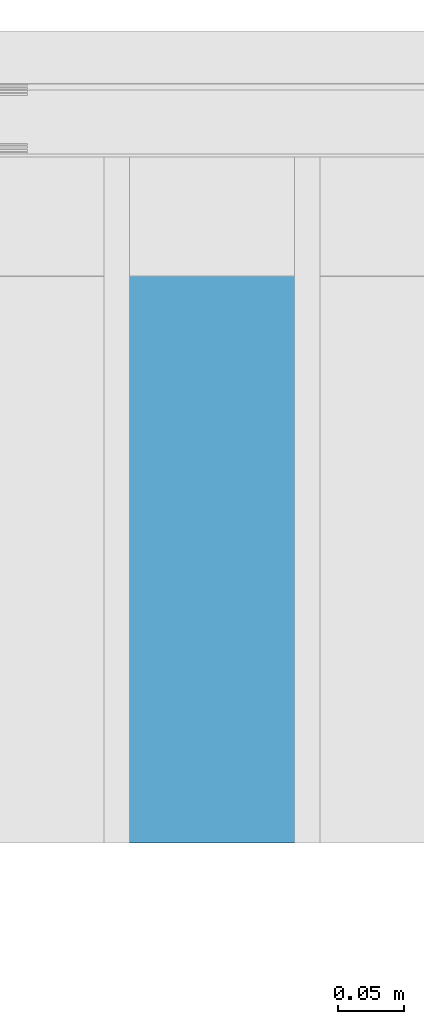
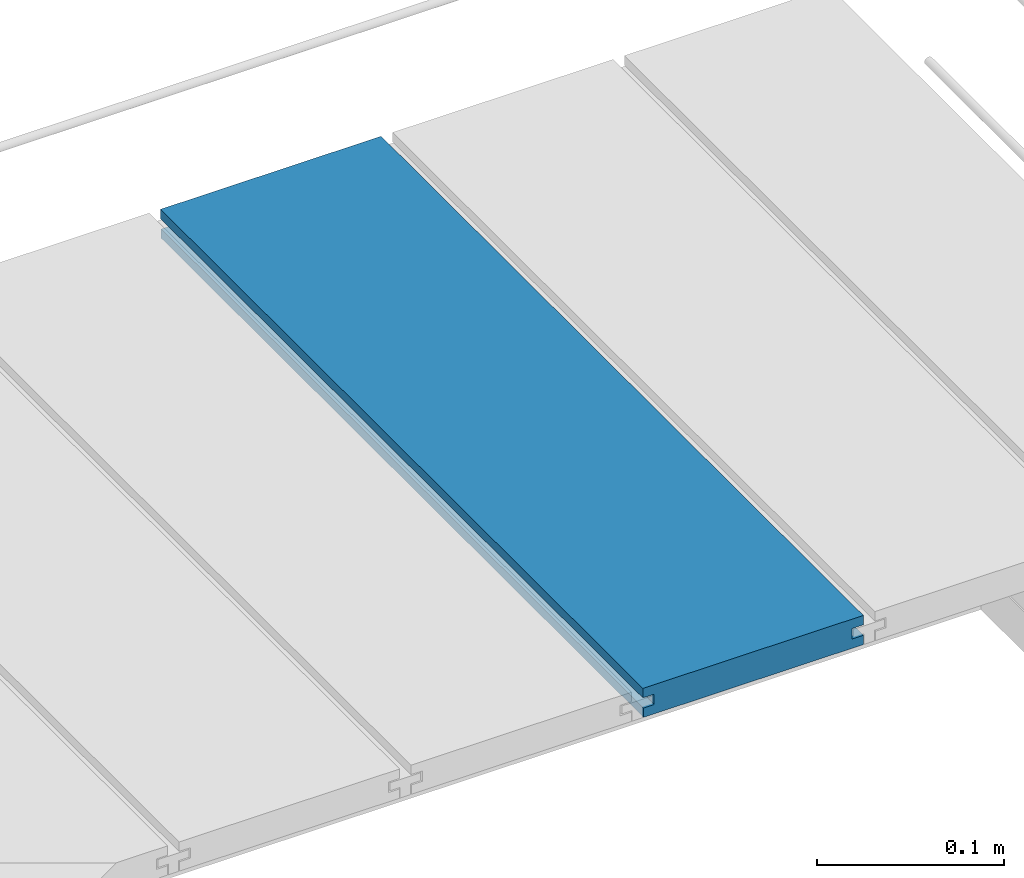
# One storey, part 17 of 33: 1 wall.
"""IFC4 building model written with IfcOpenShell, lengths in feet."""

import ifcopenshell
import ifcopenshell.guid

model = None  # the IFC model being written
_history = None  # IfcOwnerHistory: only IFC2X3 demands one
_inside = {}  # id of a spatial element -> (the spatial element, [elements in it])
_under = {}  # id of a project, library or spatial element -> (it, [spatial elements below it])
_declared = {}  # id of a project -> (the project, [libraries it declares])
_typed = {}  # id of a type object -> (the type object, [elements of that type])
_made_of = {}  # id of a material, layer set ... -> (it, [elements and type objects made of it])


def new_model(schema):
    """Start an empty IFC model of exactly this schema.

    Asked for "IFC4X3", IfcOpenShell would pick the latest addendum, in which some entities
    have other attributes; the version numbers below select the first issue.
    IFC2X3 requires an IfcOwnerHistory on every rooted entity: one is made here for all.
    """
    global model, _history
    if schema == "IFC4X3":
        model = ifcopenshell.file(schema_version=(4, 3, 0, 0))
    else:
        model = ifcopenshell.file(schema=schema)
    _inside.clear()
    _under.clear()
    _declared.clear()
    _typed.clear()
    _made_of.clear()
    _history = None
    if model.schema == "IFC2X3":
        org = make("IfcOrganization", Name="unknown")
        user = make(
            "IfcPersonAndOrganization",
            ThePerson=make("IfcPerson", FamilyName="unknown"),
            TheOrganization=org,
        )
        app = make(
            "IfcApplication",
            ApplicationDeveloper=org,
            Version="unknown",
            ApplicationFullName="unknown",
            ApplicationIdentifier="unknown",
        )
        _history = make(
            "IfcOwnerHistory",
            OwningUser=user,
            OwningApplication=app,
            ChangeAction="ADDED",
            CreationDate=0,
        )
    return model


def make(cls, **values):
    """One entity of the class cls with the attributes given. An attribute that is None is left unset."""
    return model.create_entity(
        cls, **{name: value for name, value in values.items() if value is not None}
    )


def entity(cls, *values):
    """Any entity or typed value of the class cls, its attributes in the order of the schema. None: left unset."""
    e = model.create_entity(cls)
    for i, value in enumerate(values):
        if value is not None:
            e[i] = value
    return e


def rooted(cls, **values):
    """An entity with a GlobalId (a new one), such as an element, a storey or a relation."""
    return make(cls, GlobalId=ifcopenshell.guid.new(), OwnerHistory=_history, **values)


def si_unit(unit_type, name, prefix=None):
    """IfcSIUnit, for example si_unit("LENGTHUNIT", "METRE", prefix="MILLI")."""
    return make("IfcSIUnit", UnitType=unit_type, Prefix=prefix, Name=name)


def converted_unit(unit_type, name, factor, base, dimensions=None, offset=None):
    """IfcConversionBasedUnit, such as the inch: factor (a typed value) times the base unit."""
    return make(
        "IfcConversionBasedUnit"
        if offset is None
        else "IfcConversionBasedUnitWithOffset",
        ConversionOffset=offset,
        Dimensions=None
        if dimensions is None
        else entity("IfcDimensionalExponents", *dimensions),
        UnitType=unit_type,
        Name=name,
        ConversionFactor=make(
            "IfcMeasureWithUnit", ValueComponent=factor, UnitComponent=base
        ),
    )


def derived_unit(unit_type, elements):
    """IfcDerivedUnit: a product of units, each with its exponent."""
    return make(
        "IfcDerivedUnit",
        Elements=[
            make("IfcDerivedUnitElement", Unit=unit, Exponent=power)
            for unit, power in elements
        ],
        UnitType=unit_type,
    )


def assignment(units):
    """IfcUnitAssignment: the units of a project."""
    return None if units is None else make("IfcUnitAssignment", Units=units)


def point(xyz):
    """IfcCartesianPoint."""
    return None if xyz is None else make("IfcCartesianPoint", Coordinates=xyz)


def direction(xyz):
    """IfcDirection."""
    return None if xyz is None else make("IfcDirection", DirectionRatios=xyz)


def frame(location, z_axis=None, x_axis=None):
    """IfcAxis2Placement3D, a coordinate frame: its origin and axes. An axis left out is left unset."""
    return make(
        "IfcAxis2Placement3D",
        Location=point(location),
        Axis=direction(z_axis),
        RefDirection=direction(x_axis),
    )


def origin():
    """The frame at (0, 0, 0) with its axes left unset."""
    return frame((0.0, 0.0, 0.0))


def place(relative_to, where):
    """IfcLocalPlacement: puts the frame where relative to a parent placement (None: the world)."""
    return make(
        "IfcLocalPlacement", PlacementRelTo=relative_to, RelativePlacement=where
    )


def context(
    kind, dimensions, precision=None, world=None, true_north=None, identifier=None
):
    """IfcGeometricRepresentationContext, for example the 3D "Model" context."""
    return make(
        "IfcGeometricRepresentationContext",
        ContextIdentifier=identifier,
        ContextType=kind,
        CoordinateSpaceDimension=dimensions,
        Precision=precision,
        WorldCoordinateSystem=world,
        TrueNorth=true_north,
    )


def subcontext(parent, identifier, kind, view, scale=None):
    """IfcGeometricRepresentationSubContext, for example "Body" below "Model"."""
    return make(
        "IfcGeometricRepresentationSubContext",
        ContextIdentifier=identifier,
        ContextType=kind,
        ParentContext=parent,
        TargetScale=scale,
        TargetView=view,
    )


def project(units=None, contexts=None):
    """IfcProject with its units and contexts."""
    return rooted(
        "IfcProject",
        Name="project",
        RepresentationContexts=contexts,
        UnitsInContext=assignment(units),
    )


def spatial(cls, under=None, at=None, **own):
    """A site, building, storey or space (cls), placed at a placement, below another one or the project."""
    s = rooted(cls, ObjectPlacement=at, **own)
    if under is not None:
        _under.setdefault(under.id(), (under, []))[1].append(s)
    return s


def shape(context_of_items, identifier, shape_type, items):
    """IfcShapeRepresentation: the items that make up one representation, for example the "Body"."""
    return make(
        "IfcShapeRepresentation",
        ContextOfItems=context_of_items,
        RepresentationIdentifier=identifier,
        RepresentationType=shape_type,
        Items=items,
    )


def material(Name=None, Category=None):
    """IfcMaterial."""
    return make("IfcMaterial", Name=Name, Category=Category)


def made_of(thing, what):
    """Note that an element or type object is made of a material, layer set ...; save() writes the relation."""
    if what is not None:
        _made_of.setdefault(what.id(), (what, []))[1].append(thing)
    return thing


def type_object(cls, material=None, **own):
    """A type object (cls), such as IfcWallType, which elements share."""
    return made_of(rooted(cls, **own), material)


def element(
    cls,
    number,
    at=None,
    inside=None,
    cuts=None,
    type_object=None,
    material=None,
    context=None,
    identifier="Body",
    shape_type=None,
    held_by="IfcProductDefinitionShape",
    body=None,
    shapes=None,
    **own,
):
    """One element of the class cls, such as IfcWall. Its Tag is "e" and its number.

    at: its placement. inside: the storey or other place that contains it. cuts: it is an
    opening in that element (IfcRelVoidsElement). A single representation is given by context,
    identifier, shape_type and body (its items); several are given by shapes. held_by: the class
    of the entity that holds the representations. save() writes the other relations.
    """
    e = rooted(cls, Tag="e%d" % number, ObjectPlacement=at, **own)
    if body is not None:
        shapes = [shape(context, identifier, shape_type, body)]
    if shapes is not None:
        e.Representation = make(held_by, Representations=shapes)
    if inside is not None:
        _inside.setdefault(inside.id(), (inside, []))[1].append(e)
    if cuts is not None:
        rooted(
            "IfcRelVoidsElement", RelatingBuildingElement=cuts, RelatedOpeningElement=e
        )
    if type_object is not None:
        _typed.setdefault(type_object.id(), (type_object, []))[1].append(e)
    return made_of(e, material)


def aggregate(whole, parts):
    """IfcRelAggregates: a whole, such as a stair, and the parts it consists of."""
    return rooted("IfcRelAggregates", RelatingObject=whole, RelatedObjects=parts)


def save(model, path):
    """Write the relations noted so far, then the file.

    IfcRelAggregates (storeys below a building ...), IfcRelContainedInSpatialStructure (elements
    in a storey), IfcRelDefinesByType, IfcRelAssociatesMaterial and IfcRelDeclares: one each for
    every whole, place, type object, material and project.
    """
    for whole, parts in _under.values():
        aggregate(whole, parts)
    for where, things in _inside.values():
        rooted(
            "IfcRelContainedInSpatialStructure",
            RelatedElements=things,
            RelatingStructure=where,
        )
    for kind, things in _typed.values():
        rooted("IfcRelDefinesByType", RelatedObjects=things, RelatingType=kind)
    for what, things in _made_of.values():
        rooted("IfcRelAssociatesMaterial", RelatedObjects=things, RelatingMaterial=what)
    for by, libraries in _declared.values():
        rooted("IfcRelDeclares", RelatingContext=by, RelatedDefinitions=libraries)
    model.write(path)


model = new_model("IFC4")

# Units and contexts
model_context = context("Model", 3, precision=0.0001, world=origin(), true_north=direction((6.12303176911189e-17, 1.0)))
body_context = subcontext(model_context, "Body", "Model", "MODEL_VIEW")
ifc_project = project(units=[converted_unit("LENGTHUNIT", "FOOT", entity("IfcRatioMeasure", 0.3048), si_unit("LENGTHUNIT", "METRE"), dimensions=[1, 0, 0, 0, 0, 0, 0]), converted_unit("AREAUNIT", "SQUARE FOOT", entity("IfcRatioMeasure", 0.09290304), si_unit("AREAUNIT", "SQUARE_METRE"), dimensions=[2, 0, 0, 0, 0, 0, 0]), converted_unit("VOLUMEUNIT", "CUBIC FOOT", entity("IfcRatioMeasure", 0.028316846592), si_unit("VOLUMEUNIT", "CUBIC_METRE"), dimensions=[3, 0, 0, 0, 0, 0, 0]), converted_unit("PLANEANGLEUNIT", "DEGREE", entity("IfcRatioMeasure", 0.0174532925199433), si_unit("PLANEANGLEUNIT", "RADIAN"), dimensions=[0, 0, 0, 0, 0, 0, 0]), si_unit("MASSUNIT", "GRAM", prefix="KILO"), derived_unit("MASSDENSITYUNIT", [(si_unit("MASSUNIT", "GRAM", prefix="KILO"), 1), (si_unit("LENGTHUNIT", "METRE"), -3)]), derived_unit("MOMENTOFINERTIAUNIT", [(si_unit("LENGTHUNIT", "METRE"), 4)]), si_unit("TIMEUNIT", "SECOND"), si_unit("FREQUENCYUNIT", "HERTZ"), si_unit("THERMODYNAMICTEMPERATUREUNIT", "DEGREE_CELSIUS"), derived_unit("THERMALTRANSMITTANCEUNIT", [(si_unit("MASSUNIT", "GRAM", prefix="KILO"), 1), (si_unit("THERMODYNAMICTEMPERATUREUNIT", "KELVIN"), -1), (si_unit("TIMEUNIT", "SECOND"), -3)]), derived_unit("VOLUMETRICFLOWRATEUNIT", [(si_unit("LENGTHUNIT", "METRE"), 3), (si_unit("TIMEUNIT", "SECOND"), -1)]), si_unit("ELECTRICCURRENTUNIT", "AMPERE"), si_unit("ELECTRICVOLTAGEUNIT", "VOLT"), si_unit("POWERUNIT", "WATT"), si_unit("FORCEUNIT", "NEWTON"), si_unit("ILLUMINANCEUNIT", "LUX"), si_unit("LUMINOUSFLUXUNIT", "LUMEN"), si_unit("LUMINOUSINTENSITYUNIT", "CANDELA"), derived_unit("USERDEFINED", [(si_unit("MASSUNIT", "GRAM", prefix="KILO"), -1), (si_unit("LENGTHUNIT", "METRE"), -2), (si_unit("TIMEUNIT", "SECOND"), 3), (si_unit("LUMINOUSFLUXUNIT", "LUMEN"), 1)]), derived_unit("LINEARVELOCITYUNIT", [(si_unit("LENGTHUNIT", "METRE"), 1), (si_unit("TIMEUNIT", "SECOND"), -1)]), si_unit("PRESSUREUNIT", "PASCAL"), derived_unit("USERDEFINED", [(si_unit("LENGTHUNIT", "METRE"), -2), (si_unit("MASSUNIT", "GRAM", prefix="KILO"), 1), (si_unit("TIMEUNIT", "SECOND"), -2)]), derived_unit("LINEARFORCEUNIT", [(si_unit("MASSUNIT", "GRAM", prefix="KILO"), 1), (si_unit("LENGTHUNIT", "METRE"), 1), (si_unit("TIMEUNIT", "SECOND"), -2), (si_unit("LENGTHUNIT", "METRE"), -1)]), derived_unit("PLANARFORCEUNIT", [(si_unit("MASSUNIT", "GRAM", prefix="KILO"), 1), (si_unit("LENGTHUNIT", "METRE"), 1), (si_unit("TIMEUNIT", "SECOND"), -2), (si_unit("LENGTHUNIT", "METRE"), -2)])], contexts=[model_context])

# Site, building, storey
site_placement = place(None, origin())
site = spatial("IfcSite", under=ifc_project, at=site_placement, CompositionType="ELEMENT")
building_placement = place(site_placement, origin())
building = spatial("IfcBuilding", under=site, at=building_placement, CompositionType="ELEMENT")
storey_placement = place(building_placement, frame((0.0, 0.0, 10.0)))
storey = spatial("IfcBuildingStorey", under=building, at=storey_placement, Name="2ND FLOOR", CompositionType="ELEMENT", Elevation=10.0000000000002)

# Wall
ifc_material = material(Name="COMPOSITE DECKING W/ HIDDEN FASTENERS", Category="Materials")
wall_type = type_object("IfcWallType", Name="Generic Models 636:Generic Models 1", PredefinedType="NOTDEFINED", material=ifc_material)
wall_placement = place(storey_placement, frame((1492.94072175076, 3.0461139299927, 0.68290215715013), z_axis=(0.0, 0.0, 1.0), x_axis=(0.0, 1.0, 0.0)))
cartesian_point_1 = entity("IfcCartesianPoint", [1.69226081335874, -0.446740923891412, 0.0])
vertex_point_1 = entity("IfcVertexPoint", cartesian_point_1)
cartesian_point_2 = entity("IfcCartesianPoint", [1.69226081335874, -0.00132475379450625, 0.0])
vertex_point_2 = entity("IfcVertexPoint", cartesian_point_2)
ifc_direction_1 = entity("IfcDirection", [0.0, 1.0, 0.0])
edge_curve_1 = entity("IfcEdgeCurve", vertex_point_1, vertex_point_2, entity("IfcTrimmedCurve", entity("IfcLine", cartesian_point_1, entity("IfcVector", ifc_direction_1, 1.0)), [cartesian_point_1], [cartesian_point_2], True, "CARTESIAN"), True)
cartesian_point_3 = entity("IfcCartesianPoint", [1.69226081335874, -0.00132475379450625, 0.0198779960861479])
vertex_point_3 = entity("IfcVertexPoint", cartesian_point_3)
ifc_direction_2 = entity("IfcDirection", [0.0, 0.0, 1.0])
edge_curve_2 = entity("IfcEdgeCurve", vertex_point_2, vertex_point_3, entity("IfcTrimmedCurve", entity("IfcLine", cartesian_point_2, entity("IfcVector", ifc_direction_2, 1.0)), [cartesian_point_2], [cartesian_point_3], True, "CARTESIAN"), True)
cartesian_point_4 = entity("IfcCartesianPoint", [1.69226081335874, -0.0228400010807945, 0.0198779960861479])
vertex_point_4 = entity("IfcVertexPoint", cartesian_point_4)
ifc_direction_3 = entity("IfcDirection", [0.0, -1.0, 0.0])
edge_curve_3 = entity("IfcEdgeCurve", vertex_point_3, vertex_point_4, entity("IfcTrimmedCurve", entity("IfcLine", cartesian_point_3, entity("IfcVector", ifc_direction_3, 1.0)), [cartesian_point_3], [cartesian_point_4], True, "CARTESIAN"), True)
cartesian_point_5 = entity("IfcCartesianPoint", [1.69226081335874, -0.0228400010807945, 0.0422987663426522])
vertex_point_5 = entity("IfcVertexPoint", cartesian_point_5)
edge_curve_4 = entity("IfcEdgeCurve", vertex_point_4, vertex_point_5, entity("IfcTrimmedCurve", entity("IfcLine", cartesian_point_4, entity("IfcVector", ifc_direction_2, 1.0)), [cartesian_point_4], [cartesian_point_5], True, "CARTESIAN"), True)
cartesian_point_6 = entity("IfcCartesianPoint", [1.69226081335874, 0.0, 0.0422987663426522])
vertex_point_6 = entity("IfcVertexPoint", cartesian_point_6)
edge_curve_5 = entity("IfcEdgeCurve", vertex_point_5, vertex_point_6, entity("IfcTrimmedCurve", entity("IfcLine", cartesian_point_5, entity("IfcVector", ifc_direction_1, 1.0)), [cartesian_point_5], [cartesian_point_6], True, "CARTESIAN"), True)
cartesian_point_7 = entity("IfcCartesianPoint", [1.69226081335874, 0.0, 0.0625000000000551])
vertex_point_7 = entity("IfcVertexPoint", cartesian_point_7)
edge_curve_6 = entity("IfcEdgeCurve", vertex_point_6, vertex_point_7, entity("IfcTrimmedCurve", entity("IfcLine", cartesian_point_6, entity("IfcVector", ifc_direction_2, 1.0)), [cartesian_point_6], [cartesian_point_7], True, "CARTESIAN"), True)
cartesian_point_8 = entity("IfcCartesianPoint", [1.69226081335874, -0.446740923891639, 0.0625])
vertex_point_8 = entity("IfcVertexPoint", cartesian_point_8)
edge_curve_7 = entity("IfcEdgeCurve", vertex_point_7, vertex_point_8, entity("IfcTrimmedCurve", entity("IfcLine", cartesian_point_7, entity("IfcVector", ifc_direction_3, 1.0)), [cartesian_point_7], [cartesian_point_8], True, "CARTESIAN"), True)
cartesian_point_9 = entity("IfcCartesianPoint", [1.69226081335874, -0.446740923891639, 0.0422987663426522])
vertex_point_9 = entity("IfcVertexPoint", cartesian_point_9)
ifc_direction_4 = entity("IfcDirection", [0.0, 0.0, -1.0])
edge_curve_8 = entity("IfcEdgeCurve", vertex_point_8, vertex_point_9, entity("IfcTrimmedCurve", entity("IfcLine", cartesian_point_8, entity("IfcVector", ifc_direction_4, 1.0)), [cartesian_point_8], [cartesian_point_9], True, "CARTESIAN"), True)
cartesian_point_10 = entity("IfcCartesianPoint", [1.69226081335874, -0.423900922810617, 0.0422987663426522])
vertex_point_10 = entity("IfcVertexPoint", cartesian_point_10)
edge_curve_9 = entity("IfcEdgeCurve", vertex_point_9, vertex_point_10, entity("IfcTrimmedCurve", entity("IfcLine", cartesian_point_9, entity("IfcVector", ifc_direction_1, 1.0)), [cartesian_point_9], [cartesian_point_10], True, "CARTESIAN"), True)
cartesian_point_11 = entity("IfcCartesianPoint", [1.69226081335874, -0.423900922810617, 0.0198779960861479])
vertex_point_11 = entity("IfcVertexPoint", cartesian_point_11)
edge_curve_10 = entity("IfcEdgeCurve", vertex_point_10, vertex_point_11, entity("IfcTrimmedCurve", entity("IfcLine", cartesian_point_10, entity("IfcVector", ifc_direction_4, 1.0)), [cartesian_point_10], [cartesian_point_11], True, "CARTESIAN"), True)
cartesian_point_12 = entity("IfcCartesianPoint", [1.69226081335874, -0.446740923891412, 0.0198779960861479])
vertex_point_12 = entity("IfcVertexPoint", cartesian_point_12)
edge_curve_11 = entity("IfcEdgeCurve", vertex_point_11, vertex_point_12, entity("IfcTrimmedCurve", entity("IfcLine", cartesian_point_11, entity("IfcVector", ifc_direction_3, 1.0)), [cartesian_point_11], [cartesian_point_12], True, "CARTESIAN"), True)
edge_curve_12 = entity("IfcEdgeCurve", vertex_point_12, vertex_point_1, entity("IfcTrimmedCurve", entity("IfcLine", cartesian_point_12, entity("IfcVector", ifc_direction_4, 1.0)), [cartesian_point_12], [cartesian_point_1], True, "CARTESIAN"), True)
ifc_direction_5 = entity("IfcDirection", [1.0, 0.0, 0.0])
cartesian_point_13 = entity("IfcCartesianPoint", [0.0, -0.446740923891412, 0.0])
vertex_point_13 = entity("IfcVertexPoint", cartesian_point_13)
cartesian_point_14 = entity("IfcCartesianPoint", [0.0, -0.446740923891412, 0.0198779960861479])
vertex_point_14 = entity("IfcVertexPoint", cartesian_point_14)
edge_curve_13 = entity("IfcEdgeCurve", vertex_point_13, vertex_point_14, entity("IfcTrimmedCurve", entity("IfcLine", cartesian_point_13, entity("IfcVector", ifc_direction_2, 1.0)), [cartesian_point_13], [cartesian_point_14], True, "CARTESIAN"), True)
cartesian_point_15 = entity("IfcCartesianPoint", [0.0, -0.423900922810617, 0.0198779960861479])
vertex_point_15 = entity("IfcVertexPoint", cartesian_point_15)
edge_curve_14 = entity("IfcEdgeCurve", vertex_point_14, vertex_point_15, entity("IfcTrimmedCurve", entity("IfcLine", cartesian_point_14, entity("IfcVector", ifc_direction_1, 1.0)), [cartesian_point_14], [cartesian_point_15], True, "CARTESIAN"), True)
cartesian_point_16 = entity("IfcCartesianPoint", [0.0, -0.423900922810617, 0.0422987663426522])
vertex_point_16 = entity("IfcVertexPoint", cartesian_point_16)
edge_curve_15 = entity("IfcEdgeCurve", vertex_point_15, vertex_point_16, entity("IfcTrimmedCurve", entity("IfcLine", cartesian_point_15, entity("IfcVector", ifc_direction_2, 1.0)), [cartesian_point_15], [cartesian_point_16], True, "CARTESIAN"), True)
cartesian_point_17 = entity("IfcCartesianPoint", [0.0, -0.446740923891639, 0.0422987663426522])
vertex_point_17 = entity("IfcVertexPoint", cartesian_point_17)
edge_curve_16 = entity("IfcEdgeCurve", vertex_point_16, vertex_point_17, entity("IfcTrimmedCurve", entity("IfcLine", cartesian_point_16, entity("IfcVector", ifc_direction_3, 1.0)), [cartesian_point_16], [cartesian_point_17], True, "CARTESIAN"), True)
cartesian_point_18 = entity("IfcCartesianPoint", [0.0, -0.446740923891639, 0.0625])
vertex_point_18 = entity("IfcVertexPoint", cartesian_point_18)
edge_curve_17 = entity("IfcEdgeCurve", vertex_point_17, vertex_point_18, entity("IfcTrimmedCurve", entity("IfcLine", cartesian_point_17, entity("IfcVector", ifc_direction_2, 1.0)), [cartesian_point_17], [cartesian_point_18], True, "CARTESIAN"), True)
cartesian_point_19 = entity("IfcCartesianPoint", [0.0, 0.0, 0.0625000000000551])
vertex_point_19 = entity("IfcVertexPoint", cartesian_point_19)
edge_curve_18 = entity("IfcEdgeCurve", vertex_point_18, vertex_point_19, entity("IfcTrimmedCurve", entity("IfcLine", cartesian_point_18, entity("IfcVector", ifc_direction_1, 1.0)), [cartesian_point_18], [cartesian_point_19], True, "CARTESIAN"), True)
cartesian_point_20 = entity("IfcCartesianPoint", [0.0, 0.0, 0.0422987663426522])
vertex_point_20 = entity("IfcVertexPoint", cartesian_point_20)
edge_curve_19 = entity("IfcEdgeCurve", vertex_point_19, vertex_point_20, entity("IfcTrimmedCurve", entity("IfcLine", cartesian_point_19, entity("IfcVector", ifc_direction_4, 1.0)), [cartesian_point_19], [cartesian_point_20], True, "CARTESIAN"), True)
cartesian_point_21 = entity("IfcCartesianPoint", [0.0, -0.0228400010807945, 0.0422987663426522])
vertex_point_21 = entity("IfcVertexPoint", cartesian_point_21)
edge_curve_20 = entity("IfcEdgeCurve", vertex_point_20, vertex_point_21, entity("IfcTrimmedCurve", entity("IfcLine", cartesian_point_20, entity("IfcVector", ifc_direction_3, 1.0)), [cartesian_point_20], [cartesian_point_21], True, "CARTESIAN"), True)
cartesian_point_22 = entity("IfcCartesianPoint", [0.0, -0.0228400010807945, 0.0198779960861479])
vertex_point_22 = entity("IfcVertexPoint", cartesian_point_22)
edge_curve_21 = entity("IfcEdgeCurve", vertex_point_21, vertex_point_22, entity("IfcTrimmedCurve", entity("IfcLine", cartesian_point_21, entity("IfcVector", ifc_direction_4, 1.0)), [cartesian_point_21], [cartesian_point_22], True, "CARTESIAN"), True)
cartesian_point_23 = entity("IfcCartesianPoint", [0.0, -0.00132475379450625, 0.0198779960861479])
vertex_point_23 = entity("IfcVertexPoint", cartesian_point_23)
edge_curve_22 = entity("IfcEdgeCurve", vertex_point_22, vertex_point_23, entity("IfcTrimmedCurve", entity("IfcLine", cartesian_point_22, entity("IfcVector", ifc_direction_1, 1.0)), [cartesian_point_22], [cartesian_point_23], True, "CARTESIAN"), True)
cartesian_point_24 = entity("IfcCartesianPoint", [0.0, -0.00132475379450625, 0.0])
vertex_point_24 = entity("IfcVertexPoint", cartesian_point_24)
edge_curve_23 = entity("IfcEdgeCurve", vertex_point_23, vertex_point_24, entity("IfcTrimmedCurve", entity("IfcLine", cartesian_point_23, entity("IfcVector", ifc_direction_4, 1.0)), [cartesian_point_23], [cartesian_point_24], True, "CARTESIAN"), True)
edge_curve_24 = entity("IfcEdgeCurve", vertex_point_24, vertex_point_13, entity("IfcTrimmedCurve", entity("IfcLine", cartesian_point_24, entity("IfcVector", ifc_direction_3, 1.0)), [cartesian_point_24], [cartesian_point_13], True, "CARTESIAN"), True)
ifc_direction_6 = entity("IfcDirection", [-1.0, 0.0, 0.0])
edge_curve_25 = entity("IfcEdgeCurve", vertex_point_13, vertex_point_1, entity("IfcTrimmedCurve", entity("IfcLine", cartesian_point_13, entity("IfcVector", ifc_direction_5, 1.0)), [cartesian_point_13], [cartesian_point_1], True, "CARTESIAN"), True)
edge_curve_26 = entity("IfcEdgeCurve", vertex_point_12, vertex_point_14, entity("IfcTrimmedCurve", entity("IfcLine", cartesian_point_14, entity("IfcVector", ifc_direction_6, 1.0)), [cartesian_point_12], [cartesian_point_14], True, "CARTESIAN"), True)
edge_curve_27 = entity("IfcEdgeCurve", vertex_point_18, vertex_point_8, entity("IfcTrimmedCurve", entity("IfcLine", cartesian_point_18, entity("IfcVector", ifc_direction_5, 1.0)), [cartesian_point_18], [cartesian_point_8], True, "CARTESIAN"), True)
edge_curve_28 = entity("IfcEdgeCurve", vertex_point_7, vertex_point_19, entity("IfcTrimmedCurve", entity("IfcLine", cartesian_point_19, entity("IfcVector", ifc_direction_6, 1.0)), [cartesian_point_7], [cartesian_point_19], True, "CARTESIAN"), True)
edge_curve_29 = entity("IfcEdgeCurve", vertex_point_6, vertex_point_20, entity("IfcTrimmedCurve", entity("IfcLine", cartesian_point_20, entity("IfcVector", ifc_direction_6, 1.0)), [cartesian_point_6], [cartesian_point_20], True, "CARTESIAN"), True)
edge_curve_30 = entity("IfcEdgeCurve", vertex_point_24, vertex_point_2, entity("IfcTrimmedCurve", entity("IfcLine", cartesian_point_24, entity("IfcVector", ifc_direction_5, 1.0)), [cartesian_point_24], [cartesian_point_2], True, "CARTESIAN"), True)
edge_curve_31 = entity("IfcEdgeCurve", vertex_point_17, vertex_point_9, entity("IfcTrimmedCurve", entity("IfcLine", cartesian_point_17, entity("IfcVector", ifc_direction_5, 1.0)), [cartesian_point_17], [cartesian_point_9], True, "CARTESIAN"), True)
edge_curve_32 = entity("IfcEdgeCurve", vertex_point_5, vertex_point_21, entity("IfcTrimmedCurve", entity("IfcLine", cartesian_point_21, entity("IfcVector", ifc_direction_6, 1.0)), [cartesian_point_5], [cartesian_point_21], True, "CARTESIAN"), True)
edge_curve_33 = entity("IfcEdgeCurve", vertex_point_4, vertex_point_22, entity("IfcTrimmedCurve", entity("IfcLine", cartesian_point_22, entity("IfcVector", ifc_direction_6, 1.0)), [cartesian_point_4], [cartesian_point_22], True, "CARTESIAN"), True)
edge_curve_34 = entity("IfcEdgeCurve", vertex_point_3, vertex_point_23, entity("IfcTrimmedCurve", entity("IfcLine", cartesian_point_23, entity("IfcVector", ifc_direction_6, 1.0)), [cartesian_point_3], [cartesian_point_23], True, "CARTESIAN"), True)
edge_curve_35 = entity("IfcEdgeCurve", vertex_point_11, vertex_point_15, entity("IfcTrimmedCurve", entity("IfcLine", cartesian_point_15, entity("IfcVector", ifc_direction_6, 1.0)), [cartesian_point_11], [cartesian_point_15], True, "CARTESIAN"), True)
edge_curve_36 = entity("IfcEdgeCurve", vertex_point_10, vertex_point_16, entity("IfcTrimmedCurve", entity("IfcLine", cartesian_point_16, entity("IfcVector", ifc_direction_6, 1.0)), [cartesian_point_10], [cartesian_point_16], True, "CARTESIAN"), True)
element("IfcWall", 1, at=wall_placement, inside=storey, type_object=wall_type, material=ifc_material, Name="Generic Models 636:Generic Models 1", ObjectType="Generic Models 636:Generic Models 1", PredefinedType="NOTDEFINED", context=body_context, shape_type="AdvancedBrep", body=[
    entity("IfcAdvancedBrep", entity("IfcClosedShell", [entity("IfcAdvancedFace", [entity("IfcFaceOuterBound", entity("IfcEdgeLoop", [entity("IfcOrientedEdge", None, None, edge_curve_1, True), entity("IfcOrientedEdge", None, None, edge_curve_2, True), entity("IfcOrientedEdge", None, None, edge_curve_3, True), entity("IfcOrientedEdge", None, None, edge_curve_4, True), entity("IfcOrientedEdge", None, None, edge_curve_5, True), entity("IfcOrientedEdge", None, None, edge_curve_6, True), entity("IfcOrientedEdge", None, None, edge_curve_7, True), entity("IfcOrientedEdge", None, None, edge_curve_8, True), entity("IfcOrientedEdge", None, None, edge_curve_9, True), entity("IfcOrientedEdge", None, None, edge_curve_10, True), entity("IfcOrientedEdge", None, None, edge_curve_11, True), entity("IfcOrientedEdge", None, None, edge_curve_12, True)]), True)], entity("IfcPlane", entity("IfcAxis2Placement3D", entity("IfcCartesianPoint", [1.69226081335874, -0.446740923891412, -0.0208333333328241]), ifc_direction_5, ifc_direction_4)), True), entity("IfcAdvancedFace", [entity("IfcFaceOuterBound", entity("IfcEdgeLoop", [entity("IfcOrientedEdge", None, None, edge_curve_13, True), entity("IfcOrientedEdge", None, None, edge_curve_14, True), entity("IfcOrientedEdge", None, None, edge_curve_15, True), entity("IfcOrientedEdge", None, None, edge_curve_16, True), entity("IfcOrientedEdge", None, None, edge_curve_17, True), entity("IfcOrientedEdge", None, None, edge_curve_18, True), entity("IfcOrientedEdge", None, None, edge_curve_19, True), entity("IfcOrientedEdge", None, None, edge_curve_20, True), entity("IfcOrientedEdge", None, None, edge_curve_21, True), entity("IfcOrientedEdge", None, None, edge_curve_22, True), entity("IfcOrientedEdge", None, None, edge_curve_23, True), entity("IfcOrientedEdge", None, None, edge_curve_24, True)]), True)], entity("IfcPlane", entity("IfcAxis2Placement3D", entity("IfcCartesianPoint", [0.0, -0.446740923891412, -0.0208333333328241]), ifc_direction_6, ifc_direction_2)), True), entity("IfcAdvancedFace", [entity("IfcFaceOuterBound", entity("IfcEdgeLoop", [entity("IfcOrientedEdge", None, None, edge_curve_13, False), entity("IfcOrientedEdge", None, None, edge_curve_25, True), entity("IfcOrientedEdge", None, None, edge_curve_12, False), entity("IfcOrientedEdge", None, None, edge_curve_26, True)]), True)], entity("IfcPlane", entity("IfcAxis2Placement3D", cartesian_point_13, ifc_direction_3, ifc_direction_5)), True), entity("IfcAdvancedFace", [entity("IfcFaceOuterBound", entity("IfcEdgeLoop", [entity("IfcOrientedEdge", None, None, edge_curve_18, False), entity("IfcOrientedEdge", None, None, edge_curve_27, True), entity("IfcOrientedEdge", None, None, edge_curve_7, False), entity("IfcOrientedEdge", None, None, edge_curve_28, True)]), True)], entity("IfcPlane", entity("IfcAxis2Placement3D", cartesian_point_18, ifc_direction_2, ifc_direction_5)), True), entity("IfcAdvancedFace", [entity("IfcFaceOuterBound", entity("IfcEdgeLoop", [entity("IfcOrientedEdge", None, None, edge_curve_19, False), entity("IfcOrientedEdge", None, None, edge_curve_28, False), entity("IfcOrientedEdge", None, None, edge_curve_6, False), entity("IfcOrientedEdge", None, None, edge_curve_29, True)]), True)], entity("IfcPlane", entity("IfcAxis2Placement3D", cartesian_point_19, ifc_direction_1, ifc_direction_5)), True), entity("IfcAdvancedFace", [entity("IfcFaceOuterBound", entity("IfcEdgeLoop", [entity("IfcOrientedEdge", None, None, edge_curve_24, False), entity("IfcOrientedEdge", None, None, edge_curve_30, True), entity("IfcOrientedEdge", None, None, edge_curve_1, False), entity("IfcOrientedEdge", None, None, edge_curve_25, False)]), True)], entity("IfcPlane", entity("IfcAxis2Placement3D", cartesian_point_24, ifc_direction_4, ifc_direction_5)), True), entity("IfcAdvancedFace", [entity("IfcFaceOuterBound", entity("IfcEdgeLoop", [entity("IfcOrientedEdge", None, None, edge_curve_17, False), entity("IfcOrientedEdge", None, None, edge_curve_31, True), entity("IfcOrientedEdge", None, None, edge_curve_8, False), entity("IfcOrientedEdge", None, None, edge_curve_27, False)]), True)], entity("IfcPlane", entity("IfcAxis2Placement3D", cartesian_point_17, ifc_direction_3, ifc_direction_5)), True), entity("IfcAdvancedFace", [entity("IfcFaceOuterBound", entity("IfcEdgeLoop", [entity("IfcOrientedEdge", None, None, edge_curve_20, False), entity("IfcOrientedEdge", None, None, edge_curve_29, False), entity("IfcOrientedEdge", None, None, edge_curve_5, False), entity("IfcOrientedEdge", None, None, edge_curve_32, True)]), True)], entity("IfcPlane", entity("IfcAxis2Placement3D", cartesian_point_20, ifc_direction_4, ifc_direction_5)), True), entity("IfcAdvancedFace", [entity("IfcFaceOuterBound", entity("IfcEdgeLoop", [entity("IfcOrientedEdge", None, None, edge_curve_21, False), entity("IfcOrientedEdge", None, None, edge_curve_32, False), entity("IfcOrientedEdge", None, None, edge_curve_4, False), entity("IfcOrientedEdge", None, None, edge_curve_33, True)]), True)], entity("IfcPlane", entity("IfcAxis2Placement3D", cartesian_point_21, ifc_direction_1, ifc_direction_5)), True), entity("IfcAdvancedFace", [entity("IfcFaceOuterBound", entity("IfcEdgeLoop", [entity("IfcOrientedEdge", None, None, edge_curve_22, False), entity("IfcOrientedEdge", None, None, edge_curve_33, False), entity("IfcOrientedEdge", None, None, edge_curve_3, False), entity("IfcOrientedEdge", None, None, edge_curve_34, True)]), True)], entity("IfcPlane", entity("IfcAxis2Placement3D", cartesian_point_22, ifc_direction_2, ifc_direction_5)), True), entity("IfcAdvancedFace", [entity("IfcFaceOuterBound", entity("IfcEdgeLoop", [entity("IfcOrientedEdge", None, None, edge_curve_23, False), entity("IfcOrientedEdge", None, None, edge_curve_34, False), entity("IfcOrientedEdge", None, None, edge_curve_2, False), entity("IfcOrientedEdge", None, None, edge_curve_30, False)]), True)], entity("IfcPlane", entity("IfcAxis2Placement3D", cartesian_point_23, ifc_direction_1, ifc_direction_5)), True), entity("IfcAdvancedFace", [entity("IfcFaceOuterBound", entity("IfcEdgeLoop", [entity("IfcOrientedEdge", None, None, edge_curve_14, False), entity("IfcOrientedEdge", None, None, edge_curve_26, False), entity("IfcOrientedEdge", None, None, edge_curve_11, False), entity("IfcOrientedEdge", None, None, edge_curve_35, True)]), True)], entity("IfcPlane", entity("IfcAxis2Placement3D", cartesian_point_14, ifc_direction_2, ifc_direction_5)), True), entity("IfcAdvancedFace", [entity("IfcFaceOuterBound", entity("IfcEdgeLoop", [entity("IfcOrientedEdge", None, None, edge_curve_15, False), entity("IfcOrientedEdge", None, None, edge_curve_35, False), entity("IfcOrientedEdge", None, None, edge_curve_10, False), entity("IfcOrientedEdge", None, None, edge_curve_36, True)]), True)], entity("IfcPlane", entity("IfcAxis2Placement3D", cartesian_point_15, ifc_direction_3, ifc_direction_5)), True), entity("IfcAdvancedFace", [entity("IfcFaceOuterBound", entity("IfcEdgeLoop", [entity("IfcOrientedEdge", None, None, edge_curve_16, False), entity("IfcOrientedEdge", None, None, edge_curve_36, False), entity("IfcOrientedEdge", None, None, edge_curve_9, False), entity("IfcOrientedEdge", None, None, edge_curve_31, False)]), True)], entity("IfcPlane", entity("IfcAxis2Placement3D", cartesian_point_16, ifc_direction_4, ifc_direction_5)), True)])),
])

save(model, "model.ifc")
